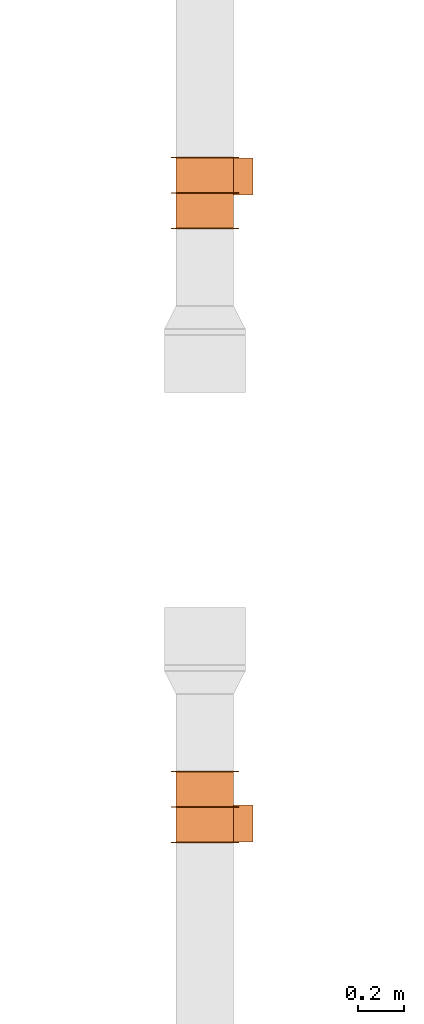
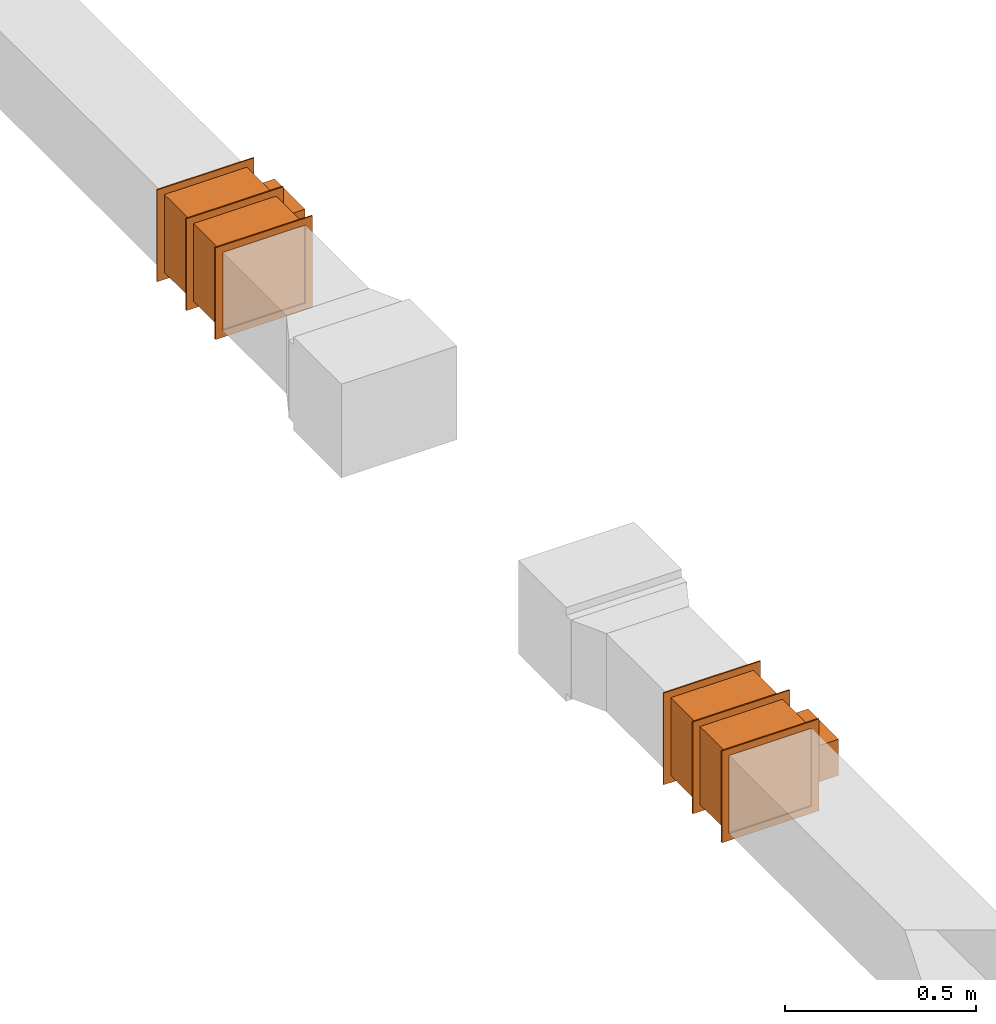
# One storey, part 3 of 3: 2 proxies.
"""IFC2X3 building model written with IfcOpenShell, lengths in millimetres."""

from ifc_helpers import new_model, entity, si_unit, converted_unit, derived_unit, direction, frame, frame_2d, origin, origin_2d_with_axis, place, context, subcontext, project, spatial, polyline, rectangle, outline, extrude, source, transform, mapped, type_object, type_shapes, element, save


model = new_model("IFC2X3")

# Units and contexts
model_context = context("Model", 3, precision=0.01, world=origin(), true_north=direction((6.12303176911189e-17, 1.0)))
body_context = subcontext(model_context, "Body", "Model", "MODEL_VIEW")
ifc_project = project(units=[si_unit("LENGTHUNIT", "METRE", prefix="MILLI"), si_unit("AREAUNIT", "SQUARE_METRE"), si_unit("VOLUMEUNIT", "CUBIC_METRE"), converted_unit("PLANEANGLEUNIT", "DEGREE", entity("IfcRatioMeasure", 0.0174532925199433), si_unit("PLANEANGLEUNIT", "RADIAN"), dimensions=[0, 0, 0, 0, 0, 0, 0]), si_unit("MASSUNIT", "GRAM", prefix="KILO"), derived_unit("MASSDENSITYUNIT", [(si_unit("MASSUNIT", "GRAM", prefix="KILO"), 1), (si_unit("LENGTHUNIT", "METRE"), -3)]), si_unit("TIMEUNIT", "SECOND"), si_unit("FREQUENCYUNIT", "HERTZ"), si_unit("THERMODYNAMICTEMPERATUREUNIT", "DEGREE_CELSIUS"), derived_unit("THERMALTRANSMITTANCEUNIT", [(si_unit("MASSUNIT", "GRAM", prefix="KILO"), 1), (si_unit("THERMODYNAMICTEMPERATUREUNIT", "KELVIN"), -1), (si_unit("TIMEUNIT", "SECOND"), -3)]), derived_unit("VOLUMETRICFLOWRATEUNIT", [(si_unit("LENGTHUNIT", "METRE"), 3), (si_unit("TIMEUNIT", "SECOND"), -1)]), si_unit("ELECTRICCURRENTUNIT", "AMPERE"), si_unit("ELECTRICVOLTAGEUNIT", "VOLT"), si_unit("POWERUNIT", "WATT"), si_unit("FORCEUNIT", "NEWTON", prefix="KILO"), si_unit("ILLUMINANCEUNIT", "LUX"), si_unit("LUMINOUSFLUXUNIT", "LUMEN"), si_unit("LUMINOUSINTENSITYUNIT", "CANDELA"), derived_unit("USERDEFINED", [(si_unit("MASSUNIT", "GRAM", prefix="KILO"), -1), (si_unit("LENGTHUNIT", "METRE"), -2), (si_unit("TIMEUNIT", "SECOND"), 3), (si_unit("LUMINOUSFLUXUNIT", "LUMEN"), 1)]), derived_unit("LINEARVELOCITYUNIT", [(si_unit("LENGTHUNIT", "METRE"), 1), (si_unit("TIMEUNIT", "SECOND"), -1)]), si_unit("PRESSUREUNIT", "PASCAL"), derived_unit("USERDEFINED", [(si_unit("LENGTHUNIT", "METRE"), -2), (si_unit("MASSUNIT", "GRAM", prefix="KILO"), 1), (si_unit("TIMEUNIT", "SECOND"), -2)])], contexts=[model_context])

# Site, building, storey
site_placement = place(None, origin())
site = spatial("IfcSite", under=ifc_project, at=site_placement, CompositionType="ELEMENT")
building_placement = place(site_placement, origin())
building = spatial("IfcBuilding", under=site, at=building_placement, CompositionType="ELEMENT")
storey_placement = place(building_placement, frame((0.0, 0.0, 8000.0)))
storey = spatial("IfcBuildingStorey", under=building, at=storey_placement, Name="02 Level", CompositionType="ELEMENT", Elevation=8000.0)

# Proxies
building_element_proxy_type_1 = type_object("IfcBuildingElementProxyType", Name="WK", PredefinedType="NOTDEFINED")
shared_shape_1 = source(origin(), body_context, "Body", "SweptSolid", [
    extrude(outline(polyline([(-147.0, -147.0), (147.0, -147.0), (147.0, 147.0), (-147.0, 147.0), (-147.0, -147.0)]), holes=[polyline([(-125.0, -125.0), (-125.0, 125.0), (125.0, 125.0), (125.0, -125.0), (-125.0, -125.0)])]), frame((151.0, 0.0, 0.0), z_axis=(1.0, 0.0, 0.0), x_axis=(0.0, 0.0, -1.0)), (0.0, 0.0, 1.0), 4.0),
    extrude(outline(polyline([(-147.0, -147.0), (147.0, -147.0), (147.0, 147.0), (-147.0, 147.0), (-147.0, -147.0)]), holes=[polyline([(-125.0, -125.0), (-125.0, 125.0), (125.0, 125.0), (125.0, -125.0), (-125.0, -125.0)])]), frame((-155.0, 0.0, 0.0), z_axis=(1.0, 0.0, 0.0), x_axis=(0.0, -1.0, 0.0)), (0.0, 0.0, 1.0), 4.0),
    extrude(outline(polyline([(-147.0, -147.0), (147.0, -147.0), (147.0, 147.0), (-147.0, 147.0), (-147.0, -147.0)]), holes=[polyline([(-125.0, -125.0), (-125.0, 125.0), (125.0, 125.0), (125.0, -125.0), (-125.0, -125.0)])]), frame((-2.0, 0.0, 0.0), z_axis=(1.0, 0.0, 0.0), x_axis=(0.0, -1.0, 0.0)), (0.0, 0.0, 1.0), 4.0),
    extrude(rectangle(XDim=302.0, YDim=250.0, at=origin_2d_with_axis()), frame((0.0, 0.0, -125.0), z_axis=(0.0, 0.0, 1.0), x_axis=(-1.0, 0.0, 0.0)), (0.0, 0.0, 1.0), 250.0),
    extrude(rectangle(XDim=84.0, YDim=160.0, at=frame_2d((-1.06581410364015e-14, 0.0), x_axis=(1.0, 0.0))), frame((71.0, -167.0, -58.0), z_axis=(0.0, 0.0, 1.0), x_axis=(0.0, -1.0, 0.0)), (0.0, 0.0, 1.0), 116.0),
])
type_shapes(building_element_proxy_type_1, [shared_shape_1])
proxy_1_placement = place(storey_placement, frame((24630.6615179764, -70160.2893332731, 3510.0), z_axis=(0.0, 0.0, -1.0), x_axis=(0.0, -1.0, 0.0)))
element("IfcBuildingElementProxy", 1, at=proxy_1_placement, inside=storey, type_object=building_element_proxy_type_1, Name="WK25-0001:WK", ObjectType="WK25-0001:WK", context=body_context, shape_type="MappedRepresentation", body=[
    mapped(shared_shape_1, transform((0.0, 0.0, 0.0), scale=1.0)),
])
building_element_proxy_type_2 = type_object("IfcBuildingElementProxyType", Name="WK", PredefinedType="NOTDEFINED")
shared_shape_2 = source(origin(), body_context, "Body", "SweptSolid", [
    extrude(outline(polyline([(-147.0, -147.0), (147.0, -147.0), (147.0, 147.0), (-147.0, 147.0), (-147.0, -147.0)]), holes=[polyline([(-125.0, -125.0), (-125.0, 125.0), (125.0, 125.0), (125.0, -125.0), (-125.0, -125.0)])]), frame((151.0, 0.0, 0.0), z_axis=(1.0, 0.0, 0.0), x_axis=(0.0, -1.0, 0.0)), (0.0, 0.0, 1.0), 4.0),
    extrude(outline(polyline([(-147.0, -147.0), (147.0, -147.0), (147.0, 147.0), (-147.0, 147.0), (-147.0, -147.0)]), holes=[polyline([(-125.0, -125.0), (-125.0, 125.0), (125.0, 125.0), (125.0, -125.0), (-125.0, -125.0)])]), frame((-155.0, 0.0, 0.0), z_axis=(1.0, 0.0, 0.0), x_axis=(0.0, 0.0, -1.0)), (0.0, 0.0, 1.0), 4.0),
    extrude(outline(polyline([(-147.0, -147.0), (147.0, -147.0), (147.0, 147.0), (-147.0, 147.0), (-147.0, -147.0)]), holes=[polyline([(-125.0, -125.0), (-125.0, 125.0), (125.0, 125.0), (125.0, -125.0), (-125.0, -125.0)])]), frame((-2.0, 0.0, 0.0), z_axis=(1.0, 0.0, 0.0), x_axis=(0.0, 0.0, -1.0)), (0.0, 0.0, 1.0), 4.0),
    extrude(rectangle(XDim=250.0, YDim=302.0, at=origin_2d_with_axis()), frame((0.0, 0.0, -125.0), z_axis=(0.0, 0.0, 1.0), x_axis=(0.0, 1.0, 0.0)), (0.0, 0.0, 1.0), 250.0),
    extrude(rectangle(XDim=160.0, YDim=84.0, at=frame_2d((0.0, -1.06581410364015e-14), x_axis=(1.0, 0.0))), frame((71.0, 167.0, -58.0)), (0.0, 0.0, 1.0), 116.0),
])
type_shapes(building_element_proxy_type_2, [shared_shape_2])
proxy_2_placement = place(storey_placement, frame((24630.6615179764, -67502.1898370068, 3510.0), z_axis=(0.0, 0.0, -1.0), x_axis=(0.0, 1.0, 0.0)))
element("IfcBuildingElementProxy", 2, at=proxy_2_placement, inside=storey, type_object=building_element_proxy_type_2, Name="WK25-0001:WK", ObjectType="WK25-0001:WK", context=body_context, shape_type="MappedRepresentation", body=[
    mapped(shared_shape_2, transform((0.0, 0.0, 0.0), scale=1.0)),
])

save(model, "model.ifc")
